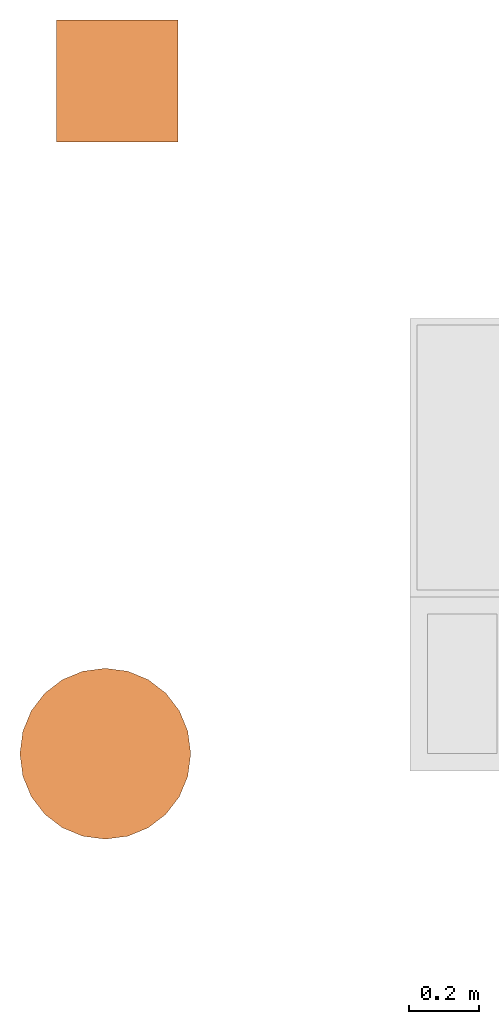
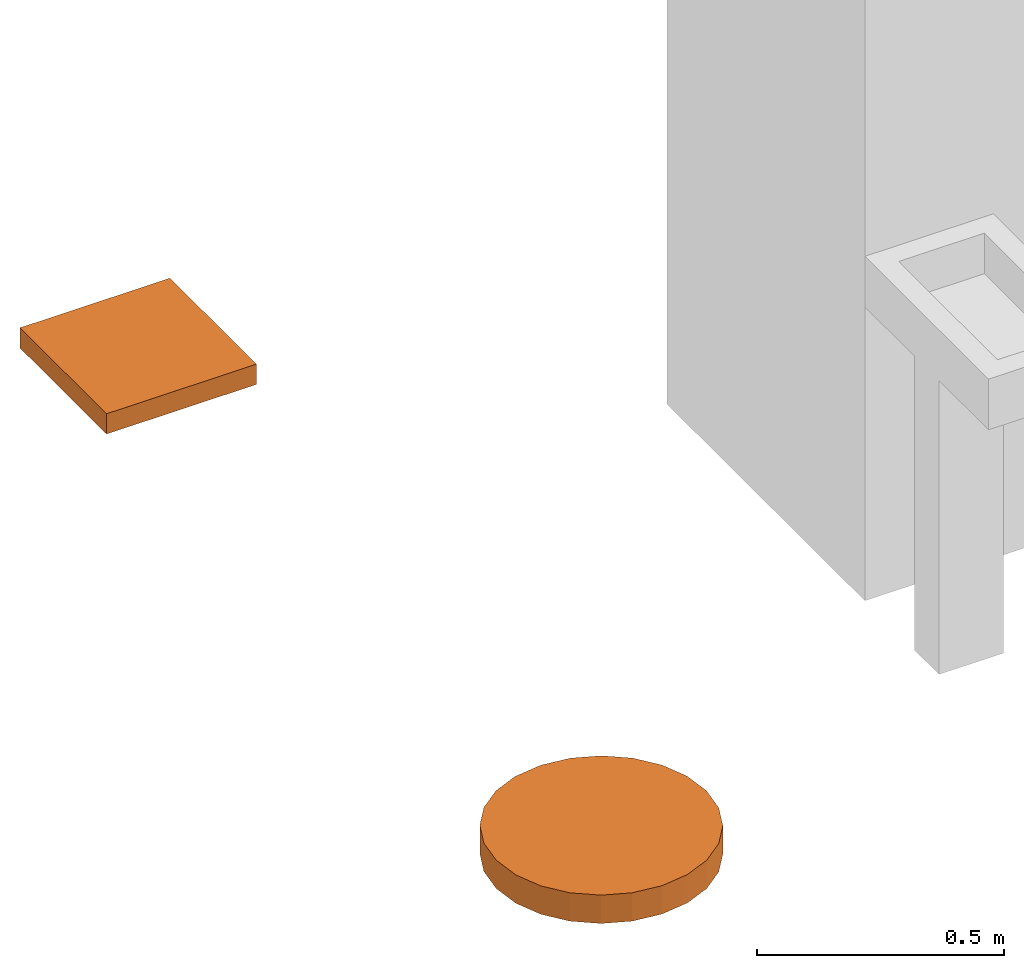
# Not in any storey, part 2 of 2: 2 proxies.
"""IFC4 model written with IfcOpenShell, lengths in millimetres."""

from ifc_helpers import new_model, entity, si_unit, converted_unit, frame, frame_2d, origin_with_axes, place, context, subcontext, project, polygons, source, transform, mapped, type_object, type_shapes, element, save


model = new_model("IFC4")

# Units and contexts
model_context = context("Model", 3, precision=1e-05, world=origin_with_axes())
plan_context = context("Plan", 2, precision=1e-05, world=frame_2d((0.0, 0.0, 0.0), x_axis=(1.0, 0.0, 0.0)))
body_context = subcontext(model_context, "Body", "Model", "MODEL_VIEW")
ifc_project = project(units=[si_unit("VOLUMEUNIT", "CUBIC_METRE", prefix="MILLI"), si_unit("LENGTHUNIT", "METRE", prefix="MILLI"), converted_unit("PLANEANGLEUNIT", "degree", entity("IfcReal", 0.0174532925199433), si_unit("PLANEANGLEUNIT", "RADIAN"), dimensions=[0, 0, 0, 0, 0, 0, 0]), si_unit("AREAUNIT", "SQUARE_METRE", prefix="MILLI")], contexts=[model_context, plan_context])

# Proxies
building_element_proxy_type_1 = type_object("IfcBuildingElementProxyType", Name="Rectangle Tag - 1:50", PredefinedType="COMPLEX")
shared_shape_1 = source(origin_with_axes(), body_context, "Body", "Tessellation", [
    polygons([(-174.999877929688, -174.999954223633, -24.9999732971191), (-174.999877929688, 174.999954223633, -24.9999732971191), (-174.999877929688, -174.999954223633, 24.9999732971191), (-174.999877929688, 174.999954223633, 24.9999732971191), (175.000030517578, 174.999954223633, -24.9999732971191), (175.000030517578, 174.999954223633, 24.9999732971191), (175.000030517578, -174.999954223633, -24.9999732971191), (175.000030517578, -174.999954223633, 24.9999732971191)], [[[3, 2, 1]], [[3, 4, 2]], [[6, 5, 2]], [[6, 2, 4]], [[6, 7, 5]], [[6, 8, 7]], [[7, 8, 3]], [[7, 3, 1]], [[2, 5, 7]], [[2, 7, 1]], [[6, 4, 3]], [[6, 3, 8]]]),
])
type_shapes(building_element_proxy_type_1, [shared_shape_1])
proxy_1_placement = place(None, frame((-641.002476215363, 2781.39090538025, -4.4703483581543e-05), z_axis=(0.0, 0.0, 1.0), x_axis=(1.0, 0.0, 0.0)))
element("IfcBuildingElementProxy", 1, at=proxy_1_placement, type_object=building_element_proxy_type_1, PredefinedType="NOTDEFINED", context=body_context, shape_type="MappedRepresentation", body=[
    mapped(shared_shape_1, transform((0.0, 0.0, 0.0), x_axis=(1.0, 0.0, 0.0), y_axis=(0.0, 1.0, 0.0), z_axis=(0.0, 0.0, 1.0), scale=1.0)),
])
building_element_proxy_type_2 = type_object("IfcBuildingElementProxyType", Name="Tag Circle - 980 - 1:50", PredefinedType="COMPLEX")
shared_shape_2 = source(origin_with_axes(), body_context, "Body", "Tessellation", [
    polygons([(-1.85985767841339, -244.999847412109, -34.9999847412109), (-1.85985767841339, -244.999847412109, 35.0000076293945), (1.8597697019577, -244.999847412109, -34.9999847412109), (1.8597697019577, -244.999847412109, 35.0000076293945), (1.8597697019577, 245.000030517578, -34.9999847412109), (1.8597697019577, 245.000030517578, 35.0000076293945), (-1.85985767841339, 245.000030517578, -34.9999847412109), (-1.85985767841339, 245.000030517578, 35.0000076293945), (-64.7891464233398, -236.715057373047, -34.9999847412109), (-123.42992401123, -212.425247192383, -34.9999847412109), (-173.785873413086, -173.785766601562, -34.9999847412109), (-212.425384521484, -123.429817199707, -34.9999847412109), (-236.715148925781, -64.7890319824219, -34.9999847412109), (-244.999969482422, -1.8597309589386, -34.9999847412109), (-244.999969482422, 1.85989630222321, -34.9999847412109), (-236.715148925781, 64.789176940918, -34.9999847412109), (-212.425384521484, 123.429954528809, -34.9999847412109), (-173.785873413086, 173.785934448242, -34.9999847412109), (-123.42992401123, 212.425445556641, -34.9999847412109), (-64.7891464233398, 236.715209960938, -34.9999847412109), (64.7890701293945, 236.715209960938, -34.9999847412109), (123.42985534668, 212.425445556641, -34.9999847412109), (173.78581237793, 173.785934448242, -34.9999847412109), (212.42529296875, 123.429954528809, -34.9999847412109), (236.715103149414, 64.789176940918, -34.9999847412109), (244.999877929688, 1.85989630222321, -34.9999847412109), (244.999877929688, -1.8597309589386, -34.9999847412109), (236.715103149414, -64.7890319824219, -34.9999847412109), (212.42529296875, -123.429817199707, -34.9999847412109), (173.78581237793, -173.785766601562, -34.9999847412109), (123.42985534668, -212.425247192383, -34.9999847412109), (64.7890701293945, -236.715057373047, -34.9999847412109), (-244.999969482422, 1.85989630222321, 35.0000076293945), (-244.999969482422, -1.8597309589386, 35.0000076293945), (-236.715148925781, -64.7890319824219, 35.0000076293945), (-212.425384521484, -123.429817199707, 35.0000076293945), (-173.785873413086, -173.785766601562, 35.0000076293945), (-123.42992401123, -212.425247192383, 35.0000076293945), (-64.7891464233398, -236.715057373047, 35.0000076293945), (64.7890701293945, -236.715057373047, 35.0000076293945), (123.42985534668, -212.425247192383, 35.0000076293945), (173.78581237793, -173.785766601562, 35.0000076293945), (212.42529296875, -123.429817199707, 35.0000076293945), (236.715103149414, -64.7890319824219, 35.0000076293945), (244.999877929688, -1.8597309589386, 35.0000076293945), (244.999877929688, 1.85989630222321, 35.0000076293945), (236.715103149414, 64.789176940918, 35.0000076293945), (212.42529296875, 123.429954528809, 35.0000076293945), (173.78581237793, 173.785934448242, 35.0000076293945), (123.42985534668, 212.425445556641, 35.0000076293945), (64.7890701293945, 236.715209960938, 35.0000076293945), (-64.7891464233398, 236.715209960938, 35.0000076293945), (-123.42992401123, 212.425445556641, 35.0000076293945), (-173.785873413086, 173.785934448242, 35.0000076293945), (-212.425384521484, 123.429954528809, 35.0000076293945), (-236.715148925781, 64.789176940918, 35.0000076293945)], [[[1, 3, 4]], [[1, 4, 2]], [[5, 7, 8]], [[5, 8, 6]], [[29, 30, 31]], [[3, 31, 32]], [[3, 29, 31]], [[27, 28, 29]], [[27, 29, 3]], [[1, 27, 3]], [[26, 27, 1]], [[24, 25, 26]], [[10, 1, 9]], [[11, 1, 10]], [[13, 11, 12]], [[13, 1, 11]], [[21, 22, 23]], [[21, 23, 24]], [[21, 24, 26]], [[14, 1, 13]], [[5, 21, 26]], [[15, 26, 1]], [[15, 1, 14]], [[7, 26, 15]], [[7, 5, 26]], [[16, 7, 15]], [[20, 7, 16]], [[18, 16, 17]], [[18, 19, 20]], [[18, 20, 16]], [[43, 41, 42]], [[4, 40, 41]], [[4, 41, 43]], [[45, 43, 44]], [[45, 4, 43]], [[2, 4, 45]], [[46, 2, 45]], [[48, 46, 47]], [[38, 39, 2]], [[37, 38, 2]], [[35, 36, 37]], [[35, 37, 2]], [[51, 48, 49]], [[51, 49, 50]], [[51, 46, 48]], [[34, 35, 2]], [[6, 46, 51]], [[33, 2, 46]], [[33, 34, 2]], [[8, 33, 46]], [[8, 46, 6]], [[56, 33, 8]], [[52, 56, 8]], [[54, 52, 53]], [[54, 55, 56]], [[54, 56, 52]], [[46, 45, 27]], [[46, 27, 26]], [[21, 5, 6]], [[21, 6, 51]], [[22, 21, 51]], [[22, 51, 50]], [[23, 22, 50]], [[23, 50, 49]], [[49, 24, 23]], [[49, 48, 24]], [[48, 25, 24]], [[48, 47, 25]], [[47, 26, 25]], [[47, 46, 26]], [[3, 40, 4]], [[3, 32, 40]], [[32, 41, 40]], [[32, 31, 41]], [[31, 42, 41]], [[31, 30, 42]], [[43, 42, 30]], [[43, 30, 29]], [[44, 43, 29]], [[44, 29, 28]], [[45, 44, 28]], [[45, 28, 27]], [[9, 1, 2]], [[9, 2, 39]], [[10, 9, 39]], [[10, 39, 38]], [[11, 10, 38]], [[11, 38, 37]], [[37, 12, 11]], [[37, 36, 12]], [[36, 13, 12]], [[36, 35, 13]], [[35, 14, 13]], [[35, 34, 14]], [[7, 52, 8]], [[7, 20, 52]], [[20, 53, 52]], [[20, 19, 53]], [[19, 54, 53]], [[19, 18, 54]], [[55, 54, 18]], [[55, 18, 17]], [[56, 55, 17]], [[56, 17, 16]], [[33, 56, 16]], [[33, 16, 15]], [[14, 33, 15]], [[14, 34, 33]]]),
])
type_shapes(building_element_proxy_type_2, [shared_shape_2])
proxy_2_placement = place(None, frame((-675.240516662598, 849.673390388489, -10.000079870224), z_axis=(0.0, 0.0, 1.0), x_axis=(1.0, 0.0, 0.0)))
element("IfcBuildingElementProxy", 2, at=proxy_2_placement, type_object=building_element_proxy_type_2, PredefinedType="NOTDEFINED", context=body_context, shape_type="MappedRepresentation", body=[
    mapped(shared_shape_2, transform((0.0, 0.0, 0.0), x_axis=(1.0, 0.0, 0.0), y_axis=(0.0, 1.0, 0.0), z_axis=(0.0, 0.0, 1.0), scale=1.0)),
])

save(model, "model.ifc")
